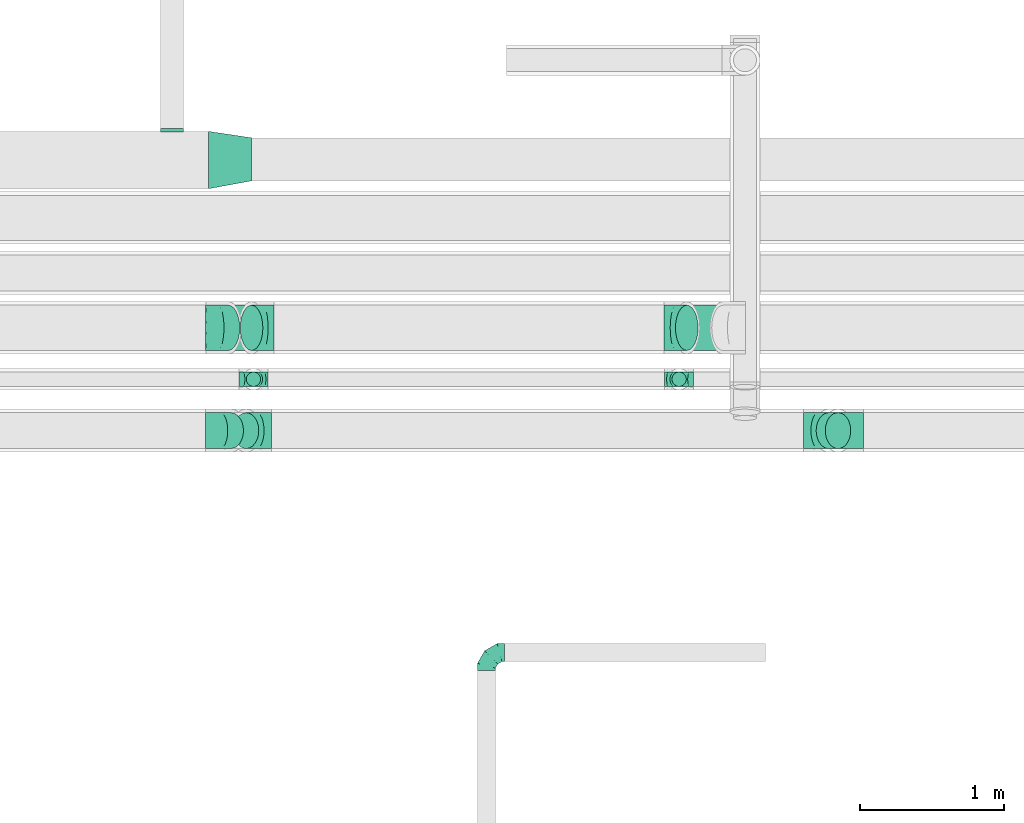
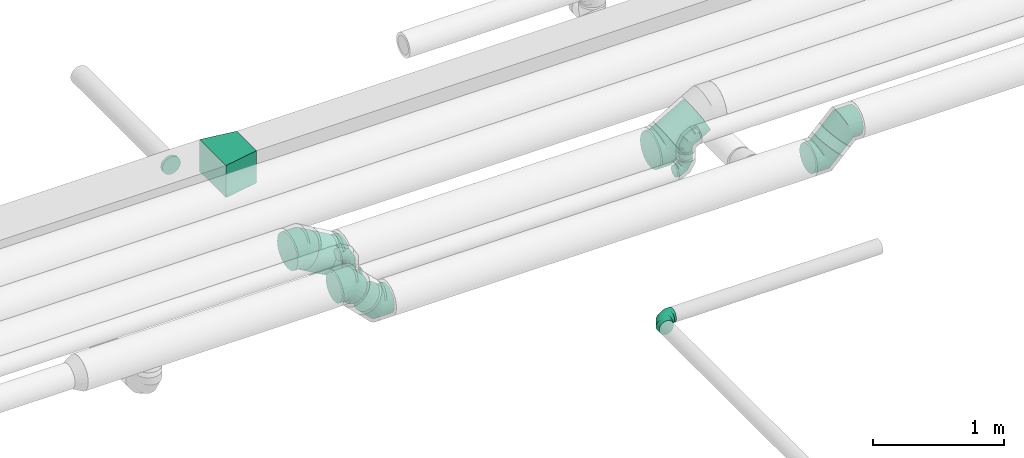
# One storey, part 54 of 92: 14 flow fittings, 5 flow segments.
"""IFC2X3 building model written with IfcOpenShell, lengths in millimetres."""

from ifc_helpers import new_model, entity, si_unit, converted_unit, derived_unit, direction, frame, origin, origin_2d_with_axis, place, context, subcontext, project, spatial, polyline, circle, outline, extrude, faceted_brep, source, transform, mapped, material, type_object, type_shapes, element, save


model = new_model("IFC2X3")

# Units and contexts
model_context = context("Model", 3, precision=0.01, world=origin(), true_north=direction((6.12303176911189e-17, 1.0)))
body_context = subcontext(model_context, "Body", "Model", "MODEL_VIEW")
ifc_project = project(units=[si_unit("LENGTHUNIT", "METRE", prefix="MILLI"), si_unit("AREAUNIT", "SQUARE_METRE"), si_unit("VOLUMEUNIT", "CUBIC_METRE"), converted_unit("PLANEANGLEUNIT", "DEGREE", entity("IfcRatioMeasure", 0.0174532925199433), si_unit("PLANEANGLEUNIT", "RADIAN"), dimensions=[0, 0, 0, 0, 0, 0, 0]), si_unit("MASSUNIT", "GRAM", prefix="KILO"), derived_unit("MASSDENSITYUNIT", [(si_unit("MASSUNIT", "GRAM", prefix="KILO"), 1), (si_unit("LENGTHUNIT", "METRE"), -3)]), derived_unit("MOMENTOFINERTIAUNIT", [(si_unit("LENGTHUNIT", "METRE"), 4)]), si_unit("TIMEUNIT", "SECOND"), si_unit("FREQUENCYUNIT", "HERTZ"), si_unit("THERMODYNAMICTEMPERATUREUNIT", "DEGREE_CELSIUS"), derived_unit("THERMALTRANSMITTANCEUNIT", [(si_unit("MASSUNIT", "GRAM", prefix="KILO"), 1), (si_unit("THERMODYNAMICTEMPERATUREUNIT", "KELVIN"), -1), (si_unit("TIMEUNIT", "SECOND"), -3)]), derived_unit("VOLUMETRICFLOWRATEUNIT", [(si_unit("LENGTHUNIT", "METRE"), 3), (si_unit("TIMEUNIT", "SECOND"), -1)]), derived_unit("MASSFLOWRATEUNIT", [(si_unit("MASSUNIT", "GRAM", prefix="KILO"), 1), (si_unit("TIMEUNIT", "SECOND"), -1)]), derived_unit("ROTATIONALFREQUENCYUNIT", [(si_unit("TIMEUNIT", "SECOND"), -1)]), si_unit("ELECTRICCURRENTUNIT", "AMPERE"), si_unit("ELECTRICVOLTAGEUNIT", "VOLT"), si_unit("POWERUNIT", "WATT"), si_unit("FORCEUNIT", "NEWTON", prefix="KILO"), si_unit("ILLUMINANCEUNIT", "LUX"), si_unit("LUMINOUSFLUXUNIT", "LUMEN"), si_unit("LUMINOUSINTENSITYUNIT", "CANDELA"), derived_unit("USERDEFINED", [(si_unit("MASSUNIT", "GRAM", prefix="KILO"), -1), (si_unit("LENGTHUNIT", "METRE"), -2), (si_unit("TIMEUNIT", "SECOND"), 3), (si_unit("LUMINOUSFLUXUNIT", "LUMEN"), 1)]), derived_unit("LINEARVELOCITYUNIT", [(si_unit("LENGTHUNIT", "METRE"), 1), (si_unit("TIMEUNIT", "SECOND"), -1)]), si_unit("PRESSUREUNIT", "PASCAL"), derived_unit("USERDEFINED", [(si_unit("LENGTHUNIT", "METRE"), -2), (si_unit("MASSUNIT", "GRAM", prefix="KILO"), 1), (si_unit("TIMEUNIT", "SECOND"), -2)]), derived_unit("LINEARFORCEUNIT", [(si_unit("MASSUNIT", "GRAM", prefix="KILO"), 1), (si_unit("LENGTHUNIT", "METRE"), 1), (si_unit("TIMEUNIT", "SECOND"), -2), (si_unit("LENGTHUNIT", "METRE"), -1)]), derived_unit("PLANARFORCEUNIT", [(si_unit("MASSUNIT", "GRAM", prefix="KILO"), 1), (si_unit("LENGTHUNIT", "METRE"), 1), (si_unit("TIMEUNIT", "SECOND"), -2), (si_unit("LENGTHUNIT", "METRE"), -2)])], contexts=[model_context])

# Site, building, storey
site_placement = place(None, origin())
site = spatial("IfcSite", under=ifc_project, at=site_placement, CompositionType="ELEMENT")
building_placement = place(site_placement, origin())
building = spatial("IfcBuilding", under=site, at=building_placement, CompositionType="ELEMENT")
storey_placement = place(building_placement, frame((0.0, 0.0, 4200.0)))
storey = spatial("IfcBuildingStorey", under=building, at=storey_placement, CompositionType="ELEMENT", Elevation=4200.0)

# Flow segments
duct_segment_type = type_object("IfcDuctSegmentType", PredefinedType="NOTDEFINED")
flow_segment_1_placement = place(storey_placement, frame((36418.01, 14797.9, 2974.21)))
element("IfcFlowSegment", 1, at=flow_segment_1_placement, inside=storey, type_object=duct_segment_type, context=body_context, shape_type="SweptSolid", body=[
    extrude(circle(Radius=157.5, at=origin_2d_with_axis()), frame((80.35, 159.1, 137.99), z_axis=(0.8660252457346, 0.0, 0.500000273750252), x_axis=(0.0, -1.0, 0.0)), (0.0, 0.0, 1.0), 291.191650198024),
])
flow_segment_2_placement = place(storey_placement, frame((33228.99, 14797.9, 2974.21)))
element("IfcFlowSegment", 2, at=flow_segment_2_placement, inside=storey, type_object=duct_segment_type, context=body_context, shape_type="SweptSolid", body=[
    extrude(circle(Radius=157.5, at=origin_2d_with_axis()), frame((241.59, 159.1, 137.99), z_axis=(-0.86602524573466, 0.0, 0.500000273750148), x_axis=(0.0, 1.0, 0.0)), (0.0, 0.0, 1.0), 186.191707685712),
])
flow_segment_3_placement = place(storey_placement, frame((33432.28, 14547.9, 3190.0)))
element("IfcFlowSegment", 3, at=flow_segment_3_placement, inside=storey, type_object=duct_segment_type, context=body_context, shape_type="SweptSolid", body=[
    extrude(circle(Radius=50.0, at=origin_2d_with_axis()), frame((51.6, 51.6, 0.0), z_axis=(0.0, 0.0, 1.0), x_axis=(0.0, 1.0, 0.0)), (0.0, 0.0, 1.0), 60.0000000000188),
])
flow_segment_4_placement = place(storey_placement, frame((36393.56, 14547.9, 3190.0)))
element("IfcFlowSegment", 4, at=flow_segment_4_placement, inside=storey, type_object=duct_segment_type, context=body_context, shape_type="SweptSolid", body=[
    extrude(circle(Radius=50.0, at=origin_2d_with_axis()), frame((51.6, 51.6, 0.0), z_axis=(0.0, 0.0, 1.0), x_axis=(0.0, -1.0, 0.0)), (0.0, 0.0, 1.0), 69.4806650488609),
])
flow_segment_5_placement = place(storey_placement, frame((37397.14, 14115.4, 3073.24)))
element("IfcFlowSegment", 5, at=flow_segment_5_placement, inside=storey, type_object=duct_segment_type, context=body_context, shape_type="SweptSolid", body=[
    extrude(circle(Radius=125.0, at=origin_2d_with_axis()), frame((89.98, 126.6, 89.98), z_axis=(0.707106781186467, 0.0, 0.707106781186628), x_axis=(0.0, -1.0, 0.0)), (0.0, 0.0, 1.0), 89.8780669117715),
])

# Flow fittings
ifc_material = material()
duct_fitting_type_1 = type_object("IfcDuctFittingType", PredefinedType="NOTDEFINED", material=ifc_material)
shared_shape_1 = source(origin(), body_context, "Body", "SweptSolid", [
    extrude(outline(polyline([(-125.72, -173.06), (177.64, -173.06), (118.3, 222.51), (-170.22, 123.62), (-125.72, -173.06)])), frame((150.0, 2.5, -150.0), z_axis=(0.0, 0.0, 1.0), x_axis=(0.988936352868278, -0.148340452930376, 0.0)), (0.0, 0.0, 1.0), 300.0),
])
type_shapes(duct_fitting_type_1, [shared_shape_1])
flow_fitting_1_placement = place(storey_placement, frame((33470.0, 16129.51, 3300.0), z_axis=(0.0, 0.0, 1.0), x_axis=(-1.0, 0.0, 0.0)))
element("IfcFlowFitting", 6, at=flow_fitting_1_placement, inside=storey, type_object=duct_fitting_type_1, material=ifc_material, context=body_context, shape_type="MappedRepresentation", body=[
    mapped(shared_shape_1, transform((0.0, 0.0, 0.0), scale=1.0)),
])
duct_fitting_type_2 = type_object("IfcDuctFittingType", PredefinedType="NOTDEFINED", material=ifc_material)
shared_shape_2 = source(origin(), body_context, "Body", "Brep", [
    faceted_brep([(-100.0, 0.0, -50.0), (-100.0, -12.94, -48.3), (-100.0, -25.0, -43.3), (-100.0, -35.36, -35.36), (-100.0, -43.3, -25.0), (-100.0, -48.3, -12.94), (-100.0, -50.0, 0.0), (-100.0, -48.3, 12.94), (-100.0, -43.3, 25.0), (-100.0, -35.36, 35.36), (-100.0, -25.0, 43.3), (-100.0, -12.94, 48.3), (-100.0, 0.0, 50.0), (-100.0, 12.94, 48.3), (-100.0, 25.0, 43.3), (-100.0, 35.36, 35.36), (-100.0, 43.3, 25.0), (-100.0, 48.3, 12.94), (-100.0, 50.0, 0.0), (-100.0, 48.3, -12.94), (-100.0, 43.3, -25.0), (-100.0, 35.36, -35.36), (-100.0, 25.0, -43.3), (-100.0, 12.94, -48.3), (-76.67, 12.94, 48.3), (-79.9, 25.0, 43.3), (-73.21, 0.0, 50.0), (-82.68, 35.36, 35.36), (-86.15, 48.3, 12.94), (-86.6, 50.0, 0.0), (-84.81, 43.3, 25.0), (-84.81, 43.3, -25.0), (-82.68, 35.36, -35.36), (-86.15, 48.3, -12.94), (-76.67, 12.94, -48.3), (-73.21, 0.0, -50.0), (-79.9, 25.0, -43.3), (-69.74, -12.94, -48.3), (-66.51, -25.0, -43.3), (-63.73, -35.36, -35.36), (-61.6, -43.3, -25.0), (-60.26, -48.3, -12.94), (-59.81, -50.0, 0.0), (-60.26, -48.3, 12.94), (-61.6, -43.3, 25.0), (-63.73, -35.36, 35.36), (-66.51, -25.0, 43.3), (-69.74, -12.94, 48.3), (-36.27, 36.27, 48.3), (-45.1, 45.1, 43.3), (-26.79, 26.79, 50.0), (-52.68, 52.68, 35.36), (-58.49, 58.49, 25.0), (-62.15, 62.15, 12.94), (-63.4, 63.4, 0.0), (-62.15, 62.15, -12.94), (-58.49, 58.49, -25.0), (-52.68, 52.68, -35.36), (-36.27, 36.27, -48.3), (-26.79, 26.79, -50.0), (-45.1, 45.1, -43.3), (-17.32, 17.32, -48.3), (-8.49, 8.49, -43.3), (-0.91, 0.91, -35.36), (4.9, -4.9, -25.0), (8.56, -8.56, -12.94), (9.81, -9.81, 0.0), (8.56, -8.56, 12.94), (4.9, -4.9, 25.0), (-0.91, 0.91, 35.36), (-8.49, 8.49, 43.3), (-17.32, 17.32, 48.3), (-12.94, 76.67, 48.3), (-25.0, 79.9, 43.3), (0.0, 73.21, 50.0), (-35.36, 82.68, 35.36), (-43.3, 84.81, 25.0), (-48.3, 86.15, 12.94), (-50.0, 86.6, 0.0), (-48.3, 86.15, -12.94), (-43.3, 84.81, -25.0), (-35.36, 82.68, -35.36), (-12.94, 76.67, -48.3), (0.0, 73.21, -50.0), (-25.0, 79.9, -43.3), (12.94, 69.74, -48.3), (25.0, 66.51, -43.3), (35.36, 63.73, -35.36), (43.3, 61.6, -25.0), (48.3, 60.26, -12.94), (50.0, 59.81, 0.0), (48.3, 60.26, 12.94), (43.3, 61.6, 25.0), (35.36, 63.73, 35.36), (25.0, 66.51, 43.3), (12.94, 69.74, 48.3), (-12.94, 100.0, -48.3), (-25.0, 100.0, -43.3), (-35.36, 100.0, -35.36), (-43.3, 100.0, -25.0), (-48.3, 100.0, -12.94), (-50.0, 100.0, 0.0), (-48.3, 100.0, 12.94), (-43.3, 100.0, 25.0), (-35.36, 100.0, 35.36), (-25.0, 100.0, 43.3), (-12.94, 100.0, 48.3), (0.0, 100.0, 50.0), (12.94, 100.0, 48.3), (25.0, 100.0, 43.3), (35.36, 100.0, 35.36), (43.3, 100.0, 25.0), (48.3, 100.0, 12.94), (50.0, 100.0, 0.0), (48.3, 100.0, -12.94), (43.3, 100.0, -25.0), (35.36, 100.0, -35.36), (25.0, 100.0, -43.3), (12.94, 100.0, -48.3), (0.0, 100.0, -50.0)], [[[0, 1, 2, 3, 4, 5, 6, 7, 8, 9, 10, 11, 12, 13, 14, 15, 16, 17, 18, 19, 20, 21, 22, 23]], [[24, 25, 14, 13]], [[26, 24, 13, 12]], [[14, 25, 27, 15]], [[28, 29, 18, 17]], [[30, 28, 17, 16]], [[15, 27, 30, 16]], [[20, 31, 32, 21]], [[33, 31, 20, 19]], [[18, 29, 33, 19]], [[34, 35, 0, 23]], [[36, 34, 23, 22]], [[32, 36, 22, 21]], [[2, 1, 37, 38]], [[3, 2, 38, 39]], [[0, 35, 37, 1]], [[5, 4, 40, 41]], [[6, 5, 41, 42]], [[3, 39, 40, 4]], [[6, 42, 43, 7]], [[7, 43, 44, 8]], [[8, 44, 45, 9]], [[10, 46, 47, 11]], [[11, 47, 26, 12]], [[10, 9, 45, 46]], [[48, 49, 25, 24]], [[50, 48, 24, 26]], [[27, 25, 49, 51]], [[52, 53, 28, 30]], [[51, 52, 30, 27]], [[29, 28, 53, 54]], [[55, 56, 31, 33]], [[54, 55, 33, 29]], [[57, 32, 31, 56]], [[58, 59, 35, 34]], [[60, 58, 34, 36]], [[57, 60, 36, 32]], [[37, 35, 59, 61]], [[38, 37, 61, 62]], [[39, 38, 62, 63]], [[41, 40, 64, 65]], [[42, 41, 65, 66]], [[63, 64, 40, 39]], [[43, 42, 66, 67]], [[44, 43, 67, 68]], [[68, 69, 45, 44]], [[46, 45, 69, 70]], [[47, 46, 70, 71]], [[26, 47, 71, 50]], [[72, 73, 49, 48]], [[74, 72, 48, 50]], [[51, 49, 73, 75]], [[76, 77, 53, 52]], [[75, 76, 52, 51]], [[54, 53, 77, 78]], [[79, 80, 56, 55]], [[78, 79, 55, 54]], [[81, 57, 56, 80]], [[82, 83, 59, 58]], [[84, 82, 58, 60]], [[81, 84, 60, 57]], [[61, 59, 83, 85]], [[62, 61, 85, 86]], [[63, 62, 86, 87]], [[65, 64, 88, 89]], [[66, 65, 89, 90]], [[87, 88, 64, 63]], [[67, 66, 90, 91]], [[68, 67, 91, 92]], [[92, 93, 69, 68]], [[70, 69, 93, 94]], [[71, 70, 94, 95]], [[50, 71, 95, 74]], [[96, 97, 98, 99, 100, 101, 102, 103, 104, 105, 106, 107, 108, 109, 110, 111, 112, 113, 114, 115, 116, 117, 118, 119]], [[72, 74, 107, 106]], [[73, 72, 106, 105]], [[75, 73, 105, 104]], [[77, 76, 103, 102]], [[78, 77, 102, 101]], [[75, 104, 103, 76]], [[78, 101, 100, 79]], [[79, 100, 99, 80]], [[80, 99, 98, 81]], [[96, 119, 83, 82]], [[97, 96, 82, 84]], [[84, 81, 98, 97]], [[83, 119, 118, 85]], [[85, 118, 117, 86]], [[86, 117, 116, 87]], [[88, 115, 114, 89]], [[89, 114, 113, 90]], [[87, 116, 115, 88]], [[91, 90, 113, 112]], [[92, 91, 112, 111]], [[93, 92, 111, 110]], [[95, 94, 109, 108]], [[74, 95, 108, 107]], [[110, 109, 94, 93]]]),
])
type_shapes(duct_fitting_type_2, [shared_shape_2])
for number, where, z_axis, x_axis in (
    (7, (33483.87, 14599.5, 3090.0), (0.0, 1.0, 0.0), (-1.0, 0.0, 0.0)),
    (8, (33483.87, 14599.5, 3350.0), (0.0, -1.0, 0.0), (0.0, 0.0, 1.0)),
    (9, (36445.15, 14599.5, 3090.0), (0.0, -1.0, 0.0), (1.0, 0.0, 0.0)),
    (10, (36445.15, 14599.5, 3359.48), (0.0, 1.0, 0.0), (0.0, 0.0, 1.0)),
):
    element("IfcFlowFitting", number, at=place(storey_placement, frame(where, z_axis=z_axis, x_axis=x_axis)), inside=storey, type_object=duct_fitting_type_2, material=ifc_material, context=body_context, shape_type="MappedRepresentation", body=[
        mapped(shared_shape_2, transform((0.0, 0.0, 0.0), scale=1.0)),
    ])
duct_fitting_type_3 = type_object("IfcDuctFittingType", PredefinedType="NOTDEFINED", material=ifc_material)
shared_shape_3 = source(origin(), body_context, "Body", "Brep", [
    faceted_brep([(-125.0, 0.0, -62.5), (-125.0, -16.18, -60.37), (-125.0, -31.25, -54.13), (-125.0, -44.19, -44.19), (-125.0, -54.13, -31.25), (-125.0, -60.37, -16.18), (-125.0, -62.5, 0.0), (-125.0, -60.37, 16.18), (-125.0, -54.13, 31.25), (-125.0, -44.19, 44.19), (-125.0, -31.25, 54.13), (-125.0, -16.18, 60.37), (-125.0, 0.0, 62.5), (-125.0, 16.18, 60.37), (-125.0, 31.25, 54.13), (-125.0, 44.19, 44.19), (-125.0, 54.13, 31.25), (-125.0, 60.37, 16.18), (-125.0, 62.5, 0.0), (-125.0, 60.37, -16.18), (-125.0, 54.13, -31.25), (-125.0, 44.19, -44.19), (-125.0, 31.25, -54.13), (-125.0, 16.18, -60.37), (-95.84, 16.18, 60.37), (-99.88, 31.25, 54.13), (-91.51, 0.0, 62.5), (-103.35, 44.19, 44.19), (-107.68, 60.37, 16.18), (-108.25, 62.5, 0.0), (-106.01, 54.13, 31.25), (-106.01, 54.13, -31.25), (-103.35, 44.19, -44.19), (-107.68, 60.37, -16.18), (-95.84, 16.18, -60.37), (-91.51, 0.0, -62.5), (-99.88, 31.25, -54.13), (-87.17, -16.18, -60.37), (-83.13, -31.25, -54.13), (-79.66, -44.19, -44.19), (-77.0, -54.13, -31.25), (-75.33, -60.37, -16.18), (-74.76, -62.5, 0.0), (-75.33, -60.37, 16.18), (-77.0, -54.13, 31.25), (-79.66, -44.19, 44.19), (-83.13, -31.25, 54.13), (-87.17, -16.18, 60.37), (-45.34, 45.34, 60.37), (-56.37, 56.37, 54.13), (-33.49, 33.49, 62.5), (-65.85, 65.85, 44.19), (-73.12, 73.12, 31.25), (-77.69, 77.69, 16.18), (-79.25, 79.25, 0.0), (-77.69, 77.69, -16.18), (-73.12, 73.12, -31.25), (-65.85, 65.85, -44.19), (-45.34, 45.34, -60.37), (-33.49, 33.49, -62.5), (-56.37, 56.37, -54.13), (-21.65, 21.65, -60.37), (-10.62, 10.62, -54.13), (-1.14, 1.14, -44.19), (6.13, -6.13, -31.25), (10.7, -10.7, -16.18), (12.26, -12.26, 0.0), (10.7, -10.7, 16.18), (6.13, -6.13, 31.25), (-1.14, 1.14, 44.19), (-10.62, 10.62, 54.13), (-21.65, 21.65, 60.37), (-16.18, 95.84, 60.37), (-31.25, 99.88, 54.13), (0.0, 91.51, 62.5), (-44.19, 103.35, 44.19), (-54.13, 106.01, 31.25), (-60.37, 107.68, 16.18), (-62.5, 108.25, 0.0), (-60.37, 107.68, -16.18), (-54.13, 106.01, -31.25), (-44.19, 103.35, -44.19), (-16.18, 95.84, -60.37), (0.0, 91.51, -62.5), (-31.25, 99.88, -54.13), (16.18, 87.17, -60.37), (31.25, 83.13, -54.13), (44.19, 79.66, -44.19), (54.13, 77.0, -31.25), (60.37, 75.33, -16.18), (62.5, 74.76, 0.0), (60.37, 75.33, 16.18), (54.13, 77.0, 31.25), (44.19, 79.66, 44.19), (31.25, 83.13, 54.13), (16.18, 87.17, 60.37), (-16.18, 125.0, -60.37), (-31.25, 125.0, -54.13), (-44.19, 125.0, -44.19), (-54.13, 125.0, -31.25), (-60.37, 125.0, -16.18), (-62.5, 125.0, 0.0), (-60.37, 125.0, 16.18), (-54.13, 125.0, 31.25), (-44.19, 125.0, 44.19), (-31.25, 125.0, 54.13), (-16.18, 125.0, 60.37), (0.0, 125.0, 62.5), (16.18, 125.0, 60.37), (31.25, 125.0, 54.13), (44.19, 125.0, 44.19), (54.13, 125.0, 31.25), (60.37, 125.0, 16.18), (62.5, 125.0, 0.0), (60.37, 125.0, -16.18), (54.13, 125.0, -31.25), (44.19, 125.0, -44.19), (31.25, 125.0, -54.13), (16.18, 125.0, -60.37), (0.0, 125.0, -62.5)], [[[0, 1, 2, 3, 4, 5, 6, 7, 8, 9, 10, 11, 12, 13, 14, 15, 16, 17, 18, 19, 20, 21, 22, 23]], [[24, 25, 14, 13]], [[26, 24, 13, 12]], [[14, 25, 27, 15]], [[28, 29, 18, 17]], [[30, 28, 17, 16]], [[15, 27, 30, 16]], [[20, 31, 32, 21]], [[33, 31, 20, 19]], [[18, 29, 33, 19]], [[34, 35, 0, 23]], [[36, 34, 23, 22]], [[21, 32, 36, 22]], [[1, 0, 35, 37]], [[2, 1, 37, 38]], [[38, 39, 3, 2]], [[5, 4, 40, 41]], [[6, 5, 41, 42]], [[39, 40, 4, 3]], [[6, 42, 43, 7]], [[7, 43, 44, 8]], [[45, 9, 8, 44]], [[9, 45, 46, 10]], [[10, 46, 47, 11]], [[26, 12, 11, 47]], [[48, 49, 25, 24]], [[50, 48, 24, 26]], [[27, 25, 49, 51]], [[52, 53, 28, 30]], [[51, 52, 30, 27]], [[29, 28, 53, 54]], [[55, 56, 31, 33]], [[54, 55, 33, 29]], [[57, 32, 31, 56]], [[58, 59, 35, 34]], [[60, 58, 34, 36]], [[57, 60, 36, 32]], [[37, 35, 59, 61]], [[38, 37, 61, 62]], [[39, 38, 62, 63]], [[41, 40, 64, 65]], [[42, 41, 65, 66]], [[63, 64, 40, 39]], [[43, 42, 66, 67]], [[44, 43, 67, 68]], [[68, 69, 45, 44]], [[46, 45, 69, 70]], [[47, 46, 70, 71]], [[26, 47, 71, 50]], [[72, 73, 49, 48]], [[74, 72, 48, 50]], [[51, 49, 73, 75]], [[76, 77, 53, 52]], [[75, 76, 52, 51]], [[54, 53, 77, 78]], [[79, 80, 56, 55]], [[78, 79, 55, 54]], [[81, 57, 56, 80]], [[82, 83, 59, 58]], [[84, 82, 58, 60]], [[81, 84, 60, 57]], [[61, 59, 83, 85]], [[62, 61, 85, 86]], [[63, 62, 86, 87]], [[65, 64, 88, 89]], [[66, 65, 89, 90]], [[87, 88, 64, 63]], [[67, 66, 90, 91]], [[68, 67, 91, 92]], [[92, 93, 69, 68]], [[70, 69, 93, 94]], [[71, 70, 94, 95]], [[50, 71, 95, 74]], [[96, 97, 98, 99, 100, 101, 102, 103, 104, 105, 106, 107, 108, 109, 110, 111, 112, 113, 114, 115, 116, 117, 118, 119]], [[72, 74, 107, 106]], [[73, 72, 106, 105]], [[75, 73, 105, 104]], [[77, 76, 103, 102]], [[78, 77, 102, 101]], [[75, 104, 103, 76]], [[78, 101, 100, 79]], [[79, 100, 99, 80]], [[80, 99, 98, 81]], [[96, 119, 83, 82]], [[97, 96, 82, 84]], [[84, 81, 98, 97]], [[83, 119, 118, 85]], [[85, 118, 117, 86]], [[116, 87, 86, 117]], [[88, 115, 114, 89]], [[89, 114, 113, 90]], [[115, 88, 87, 116]], [[91, 90, 113, 112]], [[92, 91, 112, 111]], [[111, 110, 93, 92]], [[95, 94, 109, 108]], [[74, 95, 108, 107]], [[110, 109, 94, 93]]]),
])
type_shapes(duct_fitting_type_3, [shared_shape_3])
flow_fitting_2_placement = place(storey_placement, frame((35104.56, 12697.96, 3300.0), z_axis=(0.0, 0.0, 1.0), x_axis=(-1.0, 0.0, 0.0)))
element("IfcFlowFitting", 11, at=flow_fitting_2_placement, inside=storey, type_object=duct_fitting_type_3, material=ifc_material, context=body_context, shape_type="MappedRepresentation", body=[
    mapped(shared_shape_3, transform((0.0, 0.0, 0.0), scale=1.0)),
])
duct_fitting_type_4 = type_object("IfcDuctFittingType", PredefinedType="NOTDEFINED", material=ifc_material)
shared_shape_4 = source(origin(), body_context, "Body", "Brep", [
    faceted_brep([(20.0, 20.71, -77.27), (20.0, 40.0, -69.28), (20.0, 56.57, -56.57), (20.0, 69.28, -40.0), (20.0, 77.27, -20.71), (20.0, 80.0, 0.0), (20.0, 77.27, 20.71), (20.0, 69.28, 40.0), (20.0, 56.57, 56.57), (20.0, 40.0, 69.28), (20.0, 20.71, 77.27), (20.0, 0.0, 80.0), (20.0, -20.71, 77.27), (20.0, -40.0, 69.28), (20.0, -56.57, 56.57), (20.0, -69.28, 40.0), (20.0, -77.27, 20.71), (20.0, -80.0, 0.0), (20.0, -77.27, -20.71), (20.0, -69.28, -40.0), (20.0, -56.57, -56.57), (20.0, -40.0, -69.28), (20.0, -20.71, -77.27), (20.0, 0.0, -80.0), (0.0, 0.0, 80.0), (0.0, 20.71, 77.27), (-6.1, 20.71, 77.27), (-6.1, 0.0, 80.0), (0.0, 40.0, 69.28), (-6.1, 40.0, 69.28), (0.0, 56.57, 56.57), (-6.1, 56.57, 56.57), (0.0, 69.28, 40.0), (0.0, 77.27, 20.71), (-6.1, 77.27, 20.71), (-6.1, 69.28, 40.0), (0.0, 80.0, 0.0), (-6.1, 80.0, 0.0), (0.0, 77.27, -20.71), (-6.1, 77.27, -20.71), (0.0, 69.28, -40.0), (-6.1, 69.28, -40.0), (0.0, 56.57, -56.57), (-6.1, 56.57, -56.57), (0.0, 40.0, -69.28), (0.0, 20.71, -77.27), (-6.1, 20.71, -77.27), (-6.1, 40.0, -69.28), (0.0, 0.0, -80.0), (-6.1, 0.0, -80.0), (0.0, -20.71, -77.27), (-6.1, -20.71, -77.27), (0.0, -40.0, -69.28), (-6.1, -40.0, -69.28), (0.0, -56.57, -56.57), (-6.1, -56.57, -56.57), (0.0, -69.28, -40.0), (0.0, -77.27, -20.71), (-6.1, -77.27, -20.71), (-6.1, -69.28, -40.0), (0.0, -80.0, 0.0), (-6.1, -80.0, 0.0), (0.0, -77.27, 20.71), (-6.1, -77.27, 20.71), (0.0, -69.28, 40.0), (-6.1, -69.28, 40.0), (0.0, -56.57, 56.57), (-6.1, -56.57, 56.57), (0.0, -40.0, 69.28), (0.0, -20.71, 77.27), (-6.1, -20.71, 77.27), (-6.1, -40.0, 69.28)], [[[0, 1, 2, 3, 4, 5, 6, 7, 8, 9, 10, 11, 12, 13, 14, 15, 16, 17, 18, 19, 20, 21, 22, 23]], [[24, 11, 10, 25, 26, 27]], [[25, 10, 9, 28, 29, 26]], [[28, 9, 8, 30, 31, 29]], [[32, 7, 6, 33, 34, 35]], [[33, 6, 5, 36, 37, 34]], [[30, 8, 7, 32, 35, 31]], [[36, 5, 4, 38, 39, 37]], [[38, 4, 3, 40, 41, 39]], [[40, 3, 2, 42, 43, 41]], [[44, 1, 0, 45, 46, 47]], [[45, 0, 23, 48, 49, 46]], [[42, 2, 1, 44, 47, 43]], [[48, 23, 22, 50, 51, 49]], [[50, 22, 21, 52, 53, 51]], [[52, 21, 20, 54, 55, 53]], [[56, 19, 18, 57, 58, 59]], [[57, 18, 17, 60, 61, 58]], [[54, 20, 19, 56, 59, 55]], [[60, 17, 16, 62, 63, 61]], [[62, 16, 15, 64, 65, 63]], [[64, 15, 14, 66, 67, 65]], [[68, 13, 12, 69, 70, 71]], [[69, 12, 11, 24, 27, 70]], [[66, 14, 13, 68, 71, 67]], [[49, 51, 53, 55, 59, 58, 61, 63, 65, 67, 71, 70, 27, 26, 29, 31, 35, 34, 37, 39, 41, 43, 47, 46]]]),
])
type_shapes(duct_fitting_type_4, [shared_shape_4])
flow_fitting_3_placement = place(storey_placement, frame((32917.52, 16324.51, 3300.0), z_axis=(0.0, 0.0, 1.0), x_axis=(0.0, 1.0, 0.0)))
element("IfcFlowFitting", 12, at=flow_fitting_3_placement, inside=storey, type_object=duct_fitting_type_4, material=ifc_material, context=body_context, shape_type="MappedRepresentation", body=[
    mapped(shared_shape_4, transform((0.0, 0.0, 0.0), scale=1.0)),
])
duct_fitting_type_5 = type_object("IfcDuctFittingType", PredefinedType="NOTDEFINED", material=ifc_material)
shared_shape_5 = source(origin(), body_context, "Body", "Brep", [
    faceted_brep([(-103.55, 0.0, -125.0), (-103.55, -32.35, -120.74), (-103.55, -62.5, -108.25), (-103.55, -88.39, -88.39), (-103.55, -108.25, -62.5), (-103.55, -120.74, -32.35), (-103.55, -125.0, 0.0), (-103.55, -120.74, 32.35), (-103.55, -108.25, 62.5), (-103.55, -88.39, 88.39), (-103.55, -62.5, 108.25), (-103.55, -32.35, 120.74), (-103.55, 0.0, 125.0), (-103.55, 32.35, 120.74), (-103.55, 62.5, 108.25), (-103.55, 88.39, 88.39), (-103.55, 108.25, 62.5), (-103.55, 120.74, 32.35), (-103.55, 125.0, 0.0), (-103.55, 120.74, -32.35), (-103.55, 108.25, -62.5), (-103.55, 88.39, -88.39), (-103.55, 62.5, -108.25), (-103.55, 32.35, -120.74), (-13.4, 32.35, 120.74), (-25.89, 62.5, 108.25), (0.0, 0.0, 125.0), (-36.61, 88.39, 88.39), (-44.84, 108.25, 62.5), (-50.01, 120.74, 32.35), (-51.78, 125.0, 0.0), (-50.01, 120.74, -32.35), (-44.84, 108.25, -62.5), (-36.61, 88.39, -88.39), (-13.4, 32.35, -120.74), (0.0, 0.0, -125.0), (-25.89, 62.5, -108.25), (13.4, -32.35, -120.74), (25.89, -62.5, -108.25), (36.61, -88.39, -88.39), (44.84, -108.25, -62.5), (50.01, -120.74, -32.35), (51.78, -125.0, 0.0), (50.01, -120.74, 32.35), (44.84, -108.25, 62.5), (36.61, -88.39, 88.39), (25.89, -62.5, 108.25), (13.4, -32.35, 120.74), (73.22, 73.22, 125.0), (50.35, 96.1, 120.74), (29.03, 117.42, 108.25), (10.72, 135.72, 88.39), (-3.32, 149.77, 62.5), (-12.15, 158.6, 32.35), (-15.17, 161.61, 0.0), (-12.15, 158.6, -32.35), (-3.32, 149.77, -62.5), (10.72, 135.72, -88.39), (29.03, 117.42, -108.25), (50.35, 96.1, -120.74), (73.22, 73.22, -125.0), (96.1, 50.35, -120.74), (117.42, 29.03, -108.25), (135.72, 10.72, -88.39), (149.77, -3.32, -62.5), (158.6, -12.15, -32.35), (161.61, -15.17, 0.0), (158.6, -12.15, 32.35), (149.77, -3.32, 62.5), (135.72, 10.72, 88.39), (117.42, 29.03, 108.25), (96.1, 50.35, 120.74)], [[[0, 1, 2, 3, 4, 5, 6, 7, 8, 9, 10, 11, 12, 13, 14, 15, 16, 17, 18, 19, 20, 21, 22, 23]], [[24, 25, 14, 13]], [[26, 24, 13, 12]], [[14, 25, 27, 15]], [[28, 29, 17, 16]], [[28, 16, 15, 27]], [[30, 18, 17, 29]], [[31, 32, 20, 19]], [[30, 31, 19, 18]], [[32, 33, 21, 20]], [[34, 35, 0, 23]], [[36, 34, 23, 22]], [[33, 36, 22, 21]], [[1, 0, 35, 37]], [[2, 1, 37, 38]], [[38, 39, 3, 2]], [[5, 4, 40, 41]], [[6, 5, 41, 42]], [[39, 40, 4, 3]], [[6, 42, 43, 7]], [[7, 43, 44, 8]], [[8, 44, 45, 9]], [[9, 45, 46, 10]], [[10, 46, 47, 11]], [[26, 12, 11, 47]], [[24, 26, 48, 49]], [[25, 24, 49, 50]], [[27, 25, 50, 51]], [[29, 28, 52, 53]], [[30, 29, 53, 54]], [[51, 52, 28, 27]], [[30, 54, 55, 31]], [[31, 55, 56, 32]], [[57, 33, 32, 56]], [[36, 58, 59, 34]], [[34, 59, 60, 35]], [[58, 36, 33, 57]], [[35, 60, 61, 37]], [[37, 61, 62, 38]], [[63, 39, 38, 62]], [[40, 64, 65, 41]], [[41, 65, 66, 42]], [[64, 40, 39, 63]], [[43, 42, 66, 67]], [[44, 43, 67, 68]], [[68, 69, 45, 44]], [[47, 46, 70, 71]], [[26, 47, 71, 48]], [[69, 70, 46, 45]], [[59, 58, 57, 56, 55, 54, 53, 52, 51, 50, 49, 48, 71, 70, 69, 68, 67, 66, 65, 64, 63, 62, 61, 60]]]),
])
type_shapes(duct_fitting_type_5, [shared_shape_5])
for number, where, z_axis, x_axis in (
    (13, (37623.9, 14242.0, 3300.0), (0.0, 1.0, 0.0), (0.707106781186472, 0.0, 0.707106781186623)),
    (14, (33252.9, 14242.0, 3342.7), (0.0, 1.0, 0.0), (1.0, 0.0, 0.0)),
    (15, (37413.9, 14242.0, 3090.0), (0.0, 1.0, 0.0), (-0.707106781186472, 0.0, -0.707106781186623)),
    (16, (33505.6, 14242.0, 3090.0), (0.0, -1.0, 0.0), (0.707106781186476, 0.0, -0.70710678118662)),
):
    element("IfcFlowFitting", number, at=place(storey_placement, frame(where, z_axis=z_axis, x_axis=x_axis)), inside=storey, type_object=duct_fitting_type_5, material=ifc_material, context=body_context, shape_type="MappedRepresentation", body=[
        mapped(shared_shape_5, transform((0.0, 0.0, 0.0), scale=1.0)),
    ])
duct_fitting_type_6 = type_object("IfcDuctFittingType", PredefinedType="NOTDEFINED", material=ifc_material)
shared_shape_6 = source(origin(), body_context, "Body", "Brep", [
    faceted_brep([(-84.4, 0.0, -157.5), (-84.4, -40.76, -152.13), (-84.4, -78.75, -136.4), (-84.4, -111.37, -111.37), (-84.4, -136.4, -78.75), (-84.4, -152.13, -40.76), (-84.4, -157.5, 0.0), (-84.4, -152.13, 40.76), (-84.4, -136.4, 78.75), (-84.4, -111.37, 111.37), (-84.4, -78.75, 136.4), (-84.4, -40.76, 152.13), (-84.4, 0.0, 157.5), (-84.4, 40.76, 152.13), (-84.4, 78.75, 136.4), (-84.4, 111.37, 111.37), (-84.4, 136.4, 78.75), (-84.4, 152.13, 40.76), (-84.4, 157.5, 0.0), (-84.4, 152.13, -40.76), (-84.4, 136.4, -78.75), (-84.4, 111.37, -111.37), (-84.4, 78.75, -136.4), (-84.4, 40.76, -152.13), (-10.92, 40.76, 152.13), (-21.1, 78.75, 136.4), (0.0, 0.0, 157.5), (-29.84, 111.37, 111.37), (-40.76, 152.13, 40.76), (-42.2, 157.5, 0.0), (-36.55, 136.4, 78.75), (-36.55, 136.4, -78.75), (-29.84, 111.37, -111.37), (-40.76, 152.13, -40.76), (-10.92, 40.76, -152.13), (0.0, 0.0, -157.5), (-21.1, 78.75, -136.4), (10.92, -40.76, -152.13), (21.1, -78.75, -136.4), (29.84, -111.37, -111.37), (36.55, -136.4, -78.75), (40.76, -152.13, -40.76), (42.2, -157.5, 0.0), (40.76, -152.13, 40.76), (36.55, -136.4, 78.75), (29.84, -111.37, 111.37), (21.1, -78.75, 136.4), (10.92, -40.76, 152.13), (52.71, 77.5, 152.13), (33.72, 110.4, 136.4), (73.1, 42.2, 157.5), (17.41, 138.65, 111.37), (4.9, 160.33, 78.75), (-2.97, 173.95, 40.76), (-5.65, 178.6, 0.0), (-2.97, 173.95, -40.76), (4.9, 160.33, -78.75), (17.41, 138.65, -111.37), (33.72, 110.4, -136.4), (52.71, 77.5, -152.13), (73.1, 42.2, -157.5), (93.48, 6.9, -152.13), (112.47, -26.0, -136.4), (128.78, -54.25, -111.37), (141.3, -75.92, -78.75), (149.16, -89.55, -40.76), (151.85, -94.2, 0.0), (149.16, -89.55, 40.76), (141.3, -75.92, 78.75), (128.78, -54.25, 111.37), (112.47, -26.0, 136.4), (93.48, 6.9, 152.13)], [[[0, 1, 2, 3, 4, 5, 6, 7, 8, 9, 10, 11, 12, 13, 14, 15, 16, 17, 18, 19, 20, 21, 22, 23]], [[24, 25, 14, 13]], [[26, 24, 13, 12]], [[14, 25, 27, 15]], [[28, 29, 18, 17]], [[30, 28, 17, 16]], [[15, 27, 30, 16]], [[20, 31, 32, 21]], [[33, 31, 20, 19]], [[18, 29, 33, 19]], [[34, 35, 0, 23]], [[36, 34, 23, 22]], [[32, 36, 22, 21]], [[1, 0, 35, 37]], [[2, 1, 37, 38]], [[38, 39, 3, 2]], [[5, 4, 40, 41]], [[6, 5, 41, 42]], [[39, 40, 4, 3]], [[6, 42, 43, 7]], [[7, 43, 44, 8]], [[8, 44, 45, 9]], [[9, 45, 46, 10]], [[10, 46, 47, 11]], [[26, 12, 11, 47]], [[48, 49, 25, 24]], [[50, 48, 24, 26]], [[27, 25, 49, 51]], [[28, 30, 52, 53]], [[29, 28, 53, 54]], [[51, 52, 30, 27]], [[29, 54, 55, 33]], [[33, 55, 56, 31]], [[57, 32, 31, 56]], [[36, 58, 59, 34]], [[34, 59, 60, 35]], [[58, 36, 32, 57]], [[35, 60, 61, 37]], [[37, 61, 62, 38]], [[63, 39, 38, 62]], [[40, 64, 65, 41]], [[41, 65, 66, 42]], [[64, 40, 39, 63]], [[43, 42, 66, 67]], [[44, 43, 67, 68]], [[68, 69, 45, 44]], [[47, 46, 70, 71]], [[26, 47, 71, 50]], [[69, 70, 46, 45]], [[59, 58, 57, 56, 55, 54, 53, 52, 51, 49, 48, 50, 71, 70, 69, 68, 67, 66, 65, 64, 63, 62, 61, 60]]]),
])
type_shapes(duct_fitting_type_6, [shared_shape_6])
for number, where, z_axis, x_axis in (
    (17, (36425.26, 14957.0, 3070.0), (0.0, -1.0, 0.0), (1.0, 0.0, 0.0)),
    (18, (33543.68, 14957.0, 3070.0), (0.0, 1.0, 0.0), (-1.0, 0.0, 0.0)),
    (19, (33236.24, 14957.0, 3247.5), (0.0, -1.0, 0.0), (-0.866025245734615, 0.0, 0.500000273750224)),
):
    element("IfcFlowFitting", number, at=place(storey_placement, frame(where, z_axis=z_axis, x_axis=x_axis)), inside=storey, type_object=duct_fitting_type_6, material=ifc_material, context=body_context, shape_type="MappedRepresentation", body=[
        mapped(shared_shape_6, transform((0.0, 0.0, 0.0), scale=1.0)),
    ])

save(model, "model.ifc")
